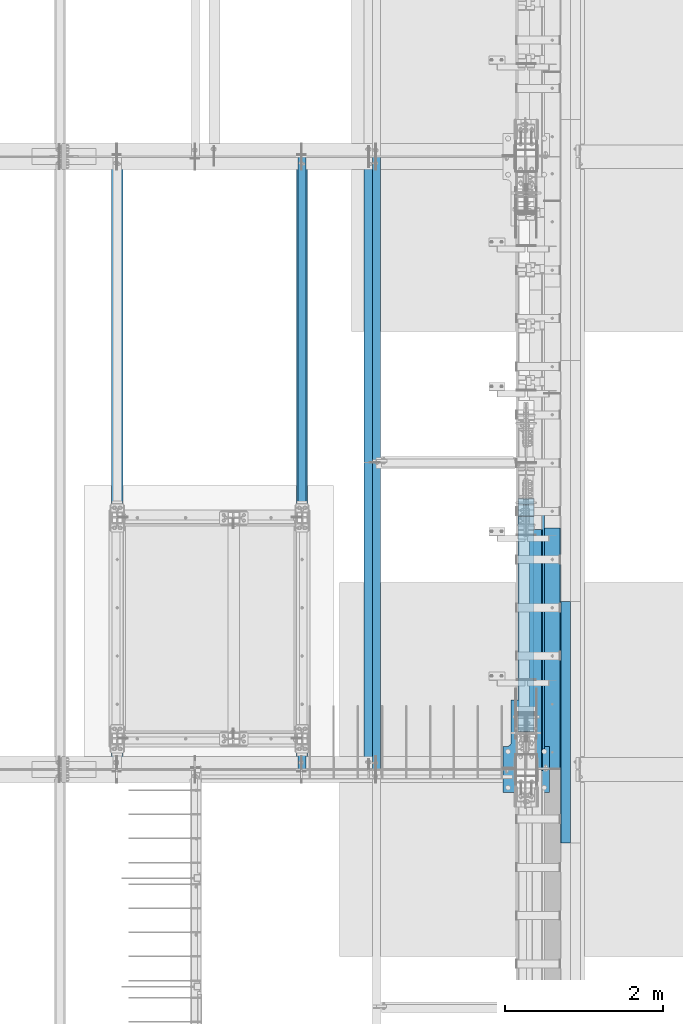
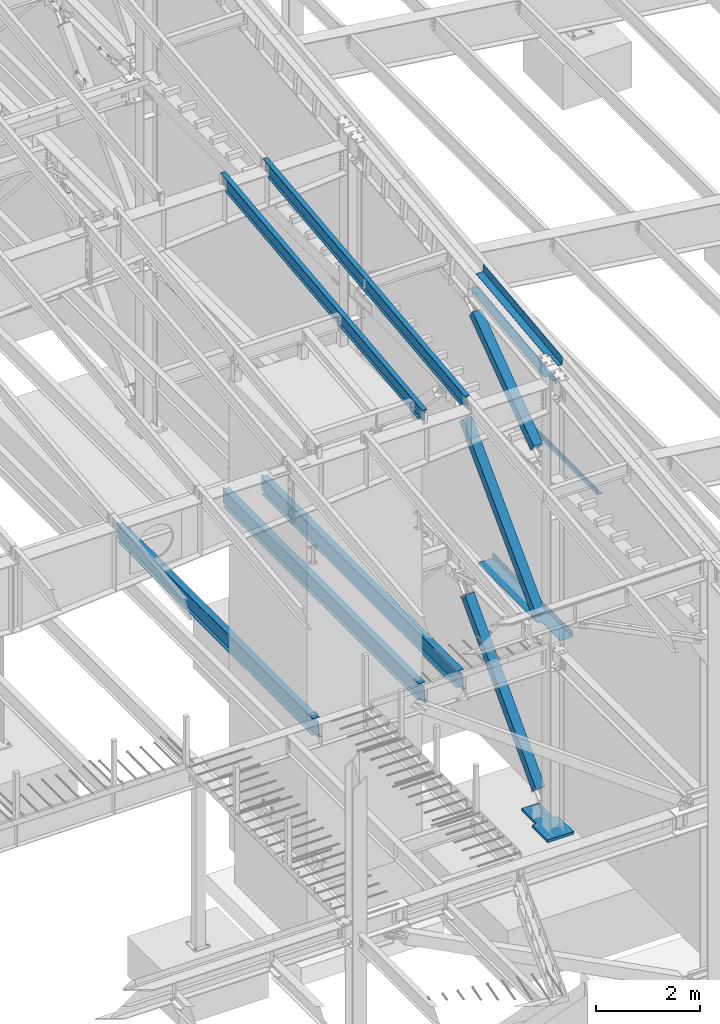
# One storey, part 723 of 1179: 10 beams, 3 members, 12 elements without a shape of their own.
"""IFC2X3 building model written with IfcOpenShell, lengths in millimetres."""

from ifc_helpers import new_model, si_unit, frame, origin_with_axes, place, context, subcontext, project, spatial, faceted_brep, material, type_object, element, aggregate, save


model = new_model("IFC2X3")

# Units and contexts
model_context = context("Model", 3, precision=1e-05, world=origin_with_axes())
body_context = subcontext(model_context, "Body", "Model", "MODEL_VIEW")
ifc_project = project(units=[si_unit("LENGTHUNIT", "METRE", prefix="MILLI"), si_unit("AREAUNIT", "SQUARE_METRE"), si_unit("VOLUMEUNIT", "CUBIC_METRE"), si_unit("MASSUNIT", "GRAM", prefix="KILO"), si_unit("TIMEUNIT", "SECOND"), si_unit("PLANEANGLEUNIT", "RADIAN"), si_unit("SOLIDANGLEUNIT", "STERADIAN"), si_unit("THERMODYNAMICTEMPERATUREUNIT", "DEGREE_CELSIUS"), si_unit("LUMINOUSINTENSITYUNIT", "LUMEN")], contexts=[model_context])

# Site, building, storey
site_placement = place(None, origin_with_axes())
site = spatial("IfcSite", under=ifc_project, at=site_placement, CompositionType="ELEMENT")
building_placement = place(site_placement, origin_with_axes())
building = spatial("IfcBuilding", under=site, at=building_placement, Name="Undefined", CompositionType="ELEMENT")
storey_placement = place(building_placement, origin_with_axes())
storey = spatial("IfcBuildingStorey", under=building, at=storey_placement, Name="Undefined", CompositionType="ELEMENT", Elevation=0.0)

# Assembly, beam
assembly_1_placement = place(storey_placement, origin_with_axes())
assembly_1 = element("IfcElementAssembly", 1, at=assembly_1_placement, inside=storey, Name="BEAM", AssemblyPlace="NOTDEFINED", PredefinedType="RIGID_FRAME")
ifc_material_1 = material(Name="STEEL/A992")
beam_type_1 = type_object("IfcBeamType", Name="W16X31", PredefinedType="NOTDEFINED")
beam_1_placement = place(assembly_1_placement, frame((21475.7, 11480.8, 3900.4875), z_axis=(0.0, 0.0, 1.0), x_axis=(0.0, 1.0, 0.0)))
beam_1 = element("IfcBeam", 2, at=beam_1_placement, type_object=beam_type_1, material=ifc_material_1, Name="BEAM", ObjectType="W16X31", context=body_context, shape_type="Brep", body=[
    faceted_brep([(104.775000190735, -3.17499999999927, 169.8625), (104.775000190735, 3.17497090526012, 169.8625), (17.4625000000015, 3.17499999999927, 169.8625), (17.4625000000015, -3.17499999999927, 169.8625), (109.635079708782, -3.17499999999927, 170.829229922588), (109.635079708782, 3.17497028100843, 170.829229922588), (113.755256176935, -3.17499999999927, 173.582243823066), (113.755256176935, 3.17496850329189, 173.582243823066), (116.508270077413, -3.17499999999927, 177.702420291219), (116.508270077413, 3.17496584275432, 177.702420291219), (117.475, -3.17499999999927, 182.562499809265), (117.475, 3.17496270443371, 182.562499809265), (117.474999999999, -69.8499999999985, 201.6125), (117.474999999999, 69.8499999999985, 201.6125), (117.474999999999, 69.8499999999985, 190.5), (117.474999999999, 3.17499999999927, 190.5), (117.474999999999, -3.17499999999927, 190.5), (117.474999999999, -69.8499999999985, 190.5), (7601.74375, 3.17499999999927, -190.5), (7601.74375, 69.8499999999985, -190.5), (144.462499999994, 69.8499999999985, -190.5), (144.462499999994, 3.17549991607666, -190.5), (17.4624999999942, -3.17499999999927, -190.5), (17.4624999999942, -69.8499999999985, -190.5), (7728.74375, -69.8499999999985, -190.5), (7728.74375, -3.17499999999927, -190.5), (17.4624999999942, -69.8499999999985, -201.6125), (7728.74375, -69.8499999999985, -201.6125), (7601.74375, 69.8499999999985, -201.6125), (7601.74375, 3.17561705897606, -201.6125), (7728.74375, 3.17561705897606, -201.6125), (17.4624999999942, 3.17549991607666, -201.6125), (144.462499999994, 3.17549991607666, -201.6125), (144.462499999994, 69.8499999999985, -201.6125), (17.4624999999942, 3.17499999999927, -190.5), (7728.74375, 3.17499999999927, -190.5), (7728.74375, 3.17499999999927, 169.8625), (7728.74375, -3.17499999999927, 169.8625), (7633.49374980927, 3.17499999999927, 169.8625), (7633.49374980927, -3.17499999999927, 169.8625), (7628.63367029122, 3.17499999999927, 170.829229922588), (7628.63367029122, -3.17499999999927, 170.829229922588), (7624.51349382307, 3.17499999999927, 173.582243823066), (7624.51349382307, -3.17499999999927, 173.582243823066), (7621.76047992259, 3.17499999999927, 177.70242029122), (7621.76047992259, -3.17499999999927, 177.70242029122), (7620.79375, 3.17499999999927, 182.562499809265), (7620.79375, -3.17499999999927, 182.562499809265), (7620.79375, -69.8499999999985, 201.6125), (7620.79375, -69.8499999999985, 190.5), (7620.79375, -3.17499999999927, 190.5), (7620.79375, 3.17499999999927, 190.5), (7620.79375, 69.8499999999985, 190.5), (7620.79375, 69.8499999999985, 201.6125)], [[[0, 1, 2, 3]], [[4, 5, 1, 0]], [[6, 7, 5, 4]], [[8, 9, 7, 6]], [[10, 11, 9, 8]], [[12, 13, 14, 15, 11, 10, 16, 17]], [[18, 19, 20, 21]], [[22, 23, 24, 25]], [[23, 26, 27, 24]], [[28, 29, 30, 27, 26, 31, 32, 33]], [[21, 32, 31, 34]], [[20, 33, 32, 21]], [[19, 28, 33, 20]], [[18, 29, 28, 19]], [[35, 30, 29, 18]], [[25, 24, 27, 30, 35, 36, 37]], [[37, 36, 38, 39]], [[39, 38, 40, 41]], [[41, 40, 42, 43]], [[43, 42, 44, 45]], [[45, 44, 46, 47]], [[48, 49, 50, 47, 46, 51, 52, 53]], [[49, 48, 12, 17]], [[50, 49, 17, 16]], [[8, 6, 4, 0, 3, 22, 25, 37, 39, 41, 43, 45, 47, 50, 16, 10]], [[34, 31, 26, 23, 22, 3, 2]], [[51, 46, 44, 42, 40, 38, 36, 35, 18, 21, 34, 2, 1, 5, 7, 9, 11, 15]], [[52, 51, 15, 14]], [[53, 52, 14, 13]], [[48, 53, 13, 12]]]),
])
aggregate(assembly_1, [beam_1])

assembly_2_placement = place(storey_placement, origin_with_axes())
assembly_2 = element("IfcElementAssembly", 3, at=assembly_2_placement, inside=storey, Name="BEAM", AssemblyPlace="NOTDEFINED", PredefinedType="RIGID_FRAME")
beam_2_placement = place(assembly_2_placement, frame((19138.9, 11480.8, 3900.4875), z_axis=(0.0, 0.0, 1.0), x_axis=(0.0, 1.0, 0.0)))
beam_2 = element("IfcBeam", 4, at=beam_2_placement, type_object=beam_type_1, material=ifc_material_1, Name="BEAM", ObjectType="W16X31", context=body_context, shape_type="Brep", body=[
    faceted_brep([(104.775000190735, -3.17499999999927, 169.8625), (104.775000190735, 3.17497090526012, 169.8625), (17.4625000000015, 3.17499999999927, 169.8625), (17.4625000000015, -3.17499999999927, 169.8625), (109.635079708782, -3.17499999999927, 170.829229922588), (109.635079708782, 3.17497028100843, 170.829229922588), (113.755256176935, -3.17499999999927, 173.582243823066), (113.755256176935, 3.17496850329189, 173.582243823066), (116.508270077413, -3.17499999999927, 177.702420291219), (116.508270077413, 3.17496584275432, 177.702420291219), (117.475, -3.17499999999927, 182.562499809265), (117.475, 3.17496270443371, 182.562499809265), (117.474999999999, -69.8499999999985, 201.6125), (117.474999999999, 69.8499999999985, 201.6125), (117.474999999999, 69.8499999999985, 190.5), (117.474999999999, 3.17499999999927, 190.5), (117.474999999999, -3.17499999999927, 190.5), (117.474999999999, -69.8499999999985, 190.5), (7601.74375, 3.17499999999927, -190.5), (7601.74375, 69.8499999999985, -190.5), (144.462499999994, 69.8499999999985, -190.5), (144.462499999994, 3.17549991607666, -190.5), (17.4624999999942, -3.17499999999927, -190.5), (17.4624999999942, -69.8499999999985, -190.5), (7728.74375, -69.8499999999985, -190.5), (7728.74375, -3.17499999999927, -190.5), (17.4624999999942, -69.8499999999985, -201.6125), (7728.74375, -69.8499999999985, -201.6125), (7601.74375, 69.8499999999985, -201.6125), (7601.74375, 3.17561705897606, -201.6125), (7728.74375, 3.17561705897606, -201.6125), (17.4624999999942, 3.17549991607666, -201.6125), (144.462499999994, 3.17549991607666, -201.6125), (144.462499999994, 69.8499999999985, -201.6125), (17.4624999999942, 3.17499999999927, -190.5), (7728.74375, 3.17499999999927, -190.5), (7728.74375, 3.17499999999927, 169.8625), (7728.74375, -3.17499999999927, 169.8625), (7633.49374980927, 3.17499999999927, 169.8625), (7633.49374980927, -3.17499999999927, 169.8625), (7628.63367029122, 3.17499999999927, 170.829229922588), (7628.63367029122, -3.17499999999927, 170.829229922588), (7624.51349382307, 3.17499999999927, 173.582243823066), (7624.51349382307, -3.17499999999927, 173.582243823066), (7621.76047992259, 3.17499999999927, 177.70242029122), (7621.76047992259, -3.17499999999927, 177.70242029122), (7620.79375, 3.17499999999927, 182.562499809265), (7620.79375, -3.17499999999927, 182.562499809265), (7620.79375, -69.8499999999985, 201.6125), (7620.79375, -69.8499999999985, 190.5), (7620.79375, -3.17499999999927, 190.5), (7620.79375, 3.17499999999927, 190.5), (7620.79375, 69.8499999999985, 190.5), (7620.79375, 69.8499999999985, 201.6125)], [[[0, 1, 2, 3]], [[4, 5, 1, 0]], [[6, 7, 5, 4]], [[8, 9, 7, 6]], [[10, 11, 9, 8]], [[12, 13, 14, 15, 11, 10, 16, 17]], [[18, 19, 20, 21]], [[22, 23, 24, 25]], [[23, 26, 27, 24]], [[28, 29, 30, 27, 26, 31, 32, 33]], [[21, 32, 31, 34]], [[20, 33, 32, 21]], [[19, 28, 33, 20]], [[18, 29, 28, 19]], [[35, 30, 29, 18]], [[25, 24, 27, 30, 35, 36, 37]], [[37, 36, 38, 39]], [[39, 38, 40, 41]], [[41, 40, 42, 43]], [[43, 42, 44, 45]], [[45, 44, 46, 47]], [[48, 49, 50, 47, 46, 51, 52, 53]], [[49, 48, 12, 17]], [[50, 49, 17, 16]], [[8, 6, 4, 0, 3, 22, 25, 37, 39, 41, 43, 45, 47, 50, 16, 10]], [[34, 31, 26, 23, 22, 3, 2]], [[51, 46, 44, 42, 40, 38, 36, 35, 18, 21, 34, 2, 1, 5, 7, 9, 11, 15]], [[52, 51, 15, 14]], [[53, 52, 14, 13]], [[48, 53, 13, 12]]]),
])
aggregate(assembly_2, [beam_2])

assembly_3_placement = place(storey_placement, origin_with_axes())
assembly_3 = element("IfcElementAssembly", 5, at=assembly_3_placement, inside=storey, Name="BEAM", AssemblyPlace="NOTDEFINED", PredefinedType="RIGID_FRAME")
beam_3_placement = place(assembly_3_placement, frame((22326.6, 11480.8, 3900.4875), z_axis=(0.0, 0.0, 1.0), x_axis=(0.0, 1.0, 0.0)))
beam_3 = element("IfcBeam", 6, at=beam_3_placement, type_object=beam_type_1, material=ifc_material_1, Name="BEAM", ObjectType="W16X31", context=body_context, shape_type="Brep", body=[
    faceted_brep([(104.775000190735, -3.17499999999927, 169.8625), (104.775000190735, 3.17497090526012, 169.8625), (17.4625000000015, 3.17499999999927, 169.8625), (17.4625000000015, -3.17499999999927, 169.8625), (109.635079708782, -3.17499999999927, 170.829229922588), (109.635079708782, 3.17497028100843, 170.829229922588), (113.755256176935, -3.17499999999927, 173.582243823066), (113.755256176935, 3.17496850329189, 173.582243823066), (116.508270077413, -3.17499999999927, 177.702420291219), (116.508270077413, 3.17496584275432, 177.702420291219), (117.475, -3.17499999999927, 182.562499809265), (117.475, 3.17496270443371, 182.562499809265), (117.474999999999, -69.8499999999985, 201.6125), (117.474999999999, 69.8499999999985, 201.6125), (117.474999999999, 69.8499999999985, 190.5), (117.474999999999, 3.17499999999927, 190.5), (117.474999999999, -3.17499999999927, 190.5), (117.474999999999, -69.8499999999985, 190.5), (7601.74375, 3.17499999999927, -190.5), (7601.74375, 69.8499999999985, -190.5), (144.462499999994, 69.8499999999985, -190.5), (144.462499999994, 3.17549991607666, -190.5), (17.4624999999942, -3.17499999999927, -190.5), (17.4624999999942, -69.8499999999985, -190.5), (7728.74375, -69.8499999999985, -190.5), (7728.74375, -3.17499999999927, -190.5), (17.4624999999942, -69.8499999999985, -201.6125), (7728.74375, -69.8499999999985, -201.6125), (7601.74375, 69.8499999999985, -201.6125), (7601.74375, 3.17561705897606, -201.6125), (7728.74375, 3.17561705897606, -201.6125), (17.4624999999942, 3.17549991607666, -201.6125), (144.462499999994, 3.17549991607666, -201.6125), (144.462499999994, 69.8499999999985, -201.6125), (17.4624999999942, 3.17499999999927, -190.5), (7728.74375, 3.17499999999927, -190.5), (7728.74375, 3.17499999999927, 169.8625), (7728.74375, -3.17499999999927, 169.8625), (7633.49374980927, 3.17499999999927, 169.8625), (7633.49374980927, -3.17499999999927, 169.8625), (7628.63367029122, 3.17499999999927, 170.829229922588), (7628.63367029122, -3.17499999999927, 170.829229922588), (7624.51349382307, 3.17499999999927, 173.582243823066), (7624.51349382307, -3.17499999999927, 173.582243823066), (7621.76047992259, 3.17499999999927, 177.70242029122), (7621.76047992259, -3.17499999999927, 177.70242029122), (7620.79375, 3.17499999999927, 182.562499809265), (7620.79375, -3.17499999999927, 182.562499809265), (7620.79375, -69.8499999999985, 201.6125), (7620.79375, -69.8499999999985, 190.5), (7620.79375, -3.17499999999927, 190.5), (7620.79375, 3.17499999999927, 190.5), (7620.79375, 69.8499999999985, 190.5), (7620.79375, 69.8499999999985, 201.6125)], [[[0, 1, 2, 3]], [[4, 5, 1, 0]], [[6, 7, 5, 4]], [[8, 9, 7, 6]], [[10, 11, 9, 8]], [[12, 13, 14, 15, 11, 10, 16, 17]], [[18, 19, 20, 21]], [[22, 23, 24, 25]], [[23, 26, 27, 24]], [[28, 29, 30, 27, 26, 31, 32, 33]], [[21, 32, 31, 34]], [[20, 33, 32, 21]], [[19, 28, 33, 20]], [[18, 29, 28, 19]], [[35, 30, 29, 18]], [[25, 24, 27, 30, 35, 36, 37]], [[37, 36, 38, 39]], [[39, 38, 40, 41]], [[41, 40, 42, 43]], [[43, 42, 44, 45]], [[45, 44, 46, 47]], [[48, 49, 50, 47, 46, 51, 52, 53]], [[49, 48, 12, 17]], [[50, 49, 17, 16]], [[8, 6, 4, 0, 3, 22, 25, 37, 39, 41, 43, 45, 47, 50, 16, 10]], [[34, 31, 26, 23, 22, 3, 2]], [[51, 46, 44, 42, 40, 38, 36, 35, 18, 21, 34, 2, 1, 5, 7, 9, 11, 15]], [[52, 51, 15, 14]], [[53, 52, 14, 13]], [[48, 53, 13, 12]]]),
])
aggregate(assembly_3, [beam_3])

assembly_4_placement = place(storey_placement, origin_with_axes())
assembly_4 = element("IfcElementAssembly", 7, at=assembly_4_placement, inside=storey, Name="BEAM", AssemblyPlace="NOTDEFINED", PredefinedType="RIGID_FRAME")
ifc_material_2 = material(Name="STEEL/A36")
beam_type_2 = type_object("IfcBeamType", PredefinedType="NOTDEFINED")
beam_4_placement = place(assembly_4_placement, frame((24350.663, 12997.8759537224, 10718.8180795381), z_axis=(0.0, -0.993676146336441, -0.112284087038017), x_axis=(1.0, 0.0, 0.0)))
beam_4 = element("IfcBeam", 8, at=beam_4_placement, type_object=beam_type_2, material=ifc_material_2, Name="BENT_PLATE", context=body_context, shape_type="Brep", body=[
    faceted_brep([(71.4352009224931, -3.17499187418616, 1106.33253533119), (71.4352351084999, 3.17500000045038, 1106.33379663171), (7.27595761418343e-12, 3.17500000044856, 1106.33381089825), (7.27595761418343e-12, -3.17499999954634, 1106.33254967412), (71.4347189428845, -3.25795323928105, 1523.99986037682), (71.4347535755223, 3.17500000061955, 1523.99999999914), (160.337000000047, -3.17500000061591, -1523.99999999915), (0.0, -3.17499999999927, -1524.0), (0.0, 3.17499999999927, -1524.0), (153.987000022519, 3.17500000077052, -1524.00000000059), (153.987000000016, 187.324999998867, -1523.99999999923), (160.337000000014, 187.324999998867, -1523.99999999923), (153.987000024775, 3.17499999922438, 1524.00000000046), (153.987000000016, 187.325000000103, 1523.99999999907), (160.337000000014, 187.325000000103, 1523.99999999907), (160.336999999981, -3.17499999938082, 1523.99999999915)], [[[0, 1, 2, 3]], [[4, 5, 1, 0]], [[6, 7, 8, 9, 10, 11]], [[9, 12, 13, 10]], [[14, 11, 10, 13]], [[15, 6, 11, 14]], [[3, 7, 6, 15, 4, 0]], [[8, 7, 3, 2]], [[12, 9, 8, 2, 1, 5]], [[15, 14, 13, 12, 5, 4]]]),
])

# Assembly, member
assembly_5_placement = place(storey_placement, origin_with_axes())
assembly_5 = element("IfcElementAssembly", 9, at=assembly_5_placement, inside=storey, Name="None", AssemblyPlace="NOTDEFINED", PredefinedType="RIGID_FRAME")
member_type = type_object("IfcMemberType", Name="HSS8X8X3/16", PredefinedType="NOTDEFINED")
member_1_placement = place(assembly_5_placement, frame((24307.8, 12102.6818031722, 8317.93316623901), z_axis=(1.0, 0.0, 0.0), x_axis=(0.0, 0.806042322895357, 0.591857899923163)))
member_1 = element("IfcMember", 10, at=member_1_placement, type_object=member_type, material=ifc_material_1, Name="None", ObjectType="HSS8X8X3/16", context=body_context, shape_type="Brep", body=[
    faceted_brep([(-3.63797880709171e-12, 96.8374999999978, -96.8375000000015), (-3.63797880709171e-12, -96.8374999999978, -96.8375000000015), (2914.65000001991, -96.8374999971984, -96.8375), (2914.65000001972, 96.8375000027499, -96.8375), (-3.63797880709171e-12, -96.8374999999978, 96.8375000000015), (2914.65000001991, -96.8374999971984, 96.8375), (-3.63797880709171e-12, 96.8374999999978, 96.8375000000015), (2914.65000001972, 96.8375000027499, 96.8375), (-3.63797880709171e-12, 101.599999999999, -101.599999999999), (-3.63797880709171e-12, 101.599999999999, 101.599999999999), (2914.65000001972, 101.600000002747, 101.6), (2914.65000001972, 101.600000002747, -101.6), (0.0, -101.599999999999, 101.599999999999), (2914.65000001991, -101.599999997197, 101.6), (0.0, -101.599999999999, -101.599999999999), (2914.65000001991, -101.599999997197, -101.6)], [[[0, 1, 2, 3]], [[1, 4, 5, 2]], [[4, 6, 7, 5]], [[6, 0, 3, 7]], [[8, 9, 10, 11]], [[9, 12, 13, 10]], [[12, 14, 15, 13]], [[14, 8, 11, 15]], [[13, 15, 11, 10], [5, 7, 3, 2]], [[14, 12, 9, 8], [6, 4, 1, 0]]]),
])
aggregate(assembly_5, [member_1])

assembly_6_placement = place(storey_placement, origin_with_axes())
assembly_6 = element("IfcElementAssembly", 11, at=assembly_6_placement, inside=storey, Name="None", AssemblyPlace="NOTDEFINED", PredefinedType="RIGID_FRAME")
member_2_placement = place(assembly_6_placement, frame((24307.8, 12024.6149486083, 4449.73744723826), z_axis=(1.0, 0.0, 0.0), x_axis=(0.0, 0.698466923036852, 0.715642339037758)))
member_2 = element("IfcMember", 12, at=member_2_placement, type_object=member_type, material=ifc_material_1, Name="None", ObjectType="HSS8X8X3/16", context=body_context, shape_type="Brep", body=[
    faceted_brep([(-3.63797880709171e-12, 96.8374999999978, -96.8375000000015), (-3.63797880709171e-12, -96.8374999999978, -96.8375000000015), (4020.12294193522, -96.8374999996613, -96.8375), (4020.12294193534, 96.8375000002416, -96.8375), (-3.63797880709171e-12, -96.8374999999978, 96.8375000000015), (4020.12294193522, -96.8374999996613, 96.8375), (-3.63797880709171e-12, 96.8374999999978, 96.8375000000015), (4020.12294193534, 96.8375000002416, 96.8375), (-3.63797880709171e-12, 101.599999999999, -101.599999999999), (-3.63797880709171e-12, 101.599999999999, 101.599999999999), (4020.12294193534, 101.600000000239, 101.6), (4020.12294193534, 101.600000000239, -101.6), (0.0, -101.599999999999, 101.599999999999), (4020.12294193522, -101.59999999966, 101.6), (0.0, -101.599999999999, -101.599999999999), (4020.12294193522, -101.59999999966, -101.6)], [[[0, 1, 2, 3]], [[1, 4, 5, 2]], [[4, 6, 7, 5]], [[6, 0, 3, 7]], [[8, 9, 10, 11]], [[9, 12, 13, 10]], [[12, 14, 15, 13]], [[14, 8, 11, 15]], [[13, 15, 11, 10], [5, 7, 3, 2]], [[14, 12, 9, 8], [6, 4, 1, 0]]]),
])
aggregate(assembly_6, [member_2])

assembly_7_placement = place(storey_placement, origin_with_axes())
assembly_7 = element("IfcElementAssembly", 13, at=assembly_7_placement, inside=storey, Name="None", AssemblyPlace="NOTDEFINED", PredefinedType="RIGID_FRAME")
member_3_placement = place(assembly_7_placement, frame((24307.8, 12032.5736527125, 369.341890750089), z_axis=(1.0, 0.0, 0.0), x_axis=(0.0, 0.685995858758672, 0.727605443744034)))
member_3 = element("IfcMember", 14, at=member_3_placement, type_object=member_type, material=ifc_material_1, Name="None", ObjectType="HSS8X8X3/16", context=body_context, shape_type="Brep", body=[
    faceted_brep([(-3.63797880709171e-12, 96.8374999999978, -96.8375000000015), (-3.63797880709171e-12, -96.8374999999978, -96.8375000000015), (3968.75000001255, -96.8375000016003, -96.8375), (3968.75000001275, 96.8374999981806, -96.8375), (-3.63797880709171e-12, -96.8374999999978, 96.8375000000015), (3968.75000001255, -96.8375000016003, 96.8375), (-3.63797880709171e-12, 96.8374999999978, 96.8375000000015), (3968.75000001275, 96.8374999981806, 96.8375), (-3.63797880709171e-12, 101.599999999999, -101.599999999999), (-3.63797880709171e-12, 101.599999999999, 101.599999999999), (3968.75000001276, 101.599999998176, 101.6), (3968.75000001276, 101.599999998176, -101.6), (0.0, -101.599999999999, 101.599999999999), (3968.75000001255, -101.600000001596, 101.6), (0.0, -101.599999999999, -101.599999999999), (3968.75000001255, -101.600000001596, -101.6)], [[[0, 1, 2, 3]], [[1, 4, 5, 2]], [[4, 6, 7, 5]], [[6, 0, 3, 7]], [[8, 9, 10, 11]], [[9, 12, 13, 10]], [[12, 14, 15, 13]], [[14, 8, 11, 15]], [[13, 15, 11, 10], [5, 7, 3, 2]], [[14, 12, 9, 8], [6, 4, 1, 0]]]),
])
aggregate(assembly_7, [member_3])

# Beam
beam_type_3 = type_object("IfcBeamType", PredefinedType="NOTDEFINED")
beam_5_placement = place(assembly_4_placement, frame((24350.6629997725, 13255.868948985, 10219.1643500463), z_axis=(0.0, -0.993676146336441, -0.112284087038017), x_axis=(1.0, 0.0, 0.0)))
beam_5 = element("IfcBeam", 15, at=beam_5_placement, type_object=beam_type_3, material=ifc_material_2, Name="BENT_PLATE", context=body_context, shape_type="Brep", body=[
    faceted_brep([(76.1995002270851, -3.17499964067611, -1324.93565701638), (76.1995002270851, 3.17561397314239, -1324.93565701637), (-7.27595761418343e-12, 3.17499999946085, -1324.93565701637), (-7.27595761418343e-12, -3.17500000053587, -1324.93565701638), (76.1995002270851, -3.17499964067065, -1309.06065701654), (76.1995002270851, 3.17561397314785, -1309.06065701656), (-7.27595761418343e-12, -3.1750000005286, -1309.06065701654), (-7.27595761418343e-12, 3.17499999946995, -1309.06065701656), (179.387000000001, -3.17499999999927, 1524.0), (179.387000000001, -3.17499999999927, -1524.0), (179.387000226754, -136.524387938527, -1523.99999999909), (179.387000226754, -136.52438793729, 1523.9999999992), (76.1995002269396, -3.17510786902676, 1377.94999996143), (76.1995002269396, 3.17550574472261, 1377.94999996396), (7.27595761418343e-12, 3.17500000055588, 1377.94999996396), (7.27595761418343e-12, -3.1749999994372, 1377.94999996142), (76.1995002269396, -3.17561361185653, 1523.999999945), (76.1995002269396, 3.17500000061045, 1523.99999999914), (185.737000226753, -136.52438793729, 1523.9999999992), (185.737000000001, 3.17499999999927, 1524.0), (185.737000000001, 3.17499999999927, -1524.0), (185.737000226753, -136.524387938527, -1523.99999999909), (0.0, -3.17499999999927, -1524.0), (0.0, 3.17499999999927, -1524.0)], [[[0, 1, 2, 3]], [[4, 5, 1, 0]], [[6, 7, 5, 4]], [[8, 9, 10, 11]], [[12, 13, 14, 15]], [[16, 17, 13, 12]], [[8, 11, 18, 19, 17, 16]], [[20, 19, 18, 21]], [[11, 10, 21, 18]], [[9, 22, 23, 20, 21, 10]], [[23, 22, 3, 2]], [[14, 13, 17, 19, 20, 23, 2, 1, 5, 7]], [[15, 14, 7, 6]], [[3, 22, 9, 8, 16, 12, 15, 6, 4, 0]]]),
])

aggregate(assembly_4, [beam_4, beam_5])

# Assembly, beam
assembly_8_placement = place(storey_placement, origin_with_axes())
assembly_8 = element("IfcElementAssembly", 16, at=assembly_8_placement, inside=storey, Name="BEAM", AssemblyPlace="NOTDEFINED", PredefinedType="RIGID_FRAME")
beam_type_4 = type_object("IfcBeamType", PredefinedType="NOTDEFINED")
beam_6_placement = place(assembly_8_placement, frame((24387.175012207, 13007.975, 4105.275), z_axis=(0.0, -1.0, 0.0), x_axis=(1.0, 0.0, 0.0)))
beam_6 = element("IfcBeam", 17, at=beam_6_placement, type_object=beam_type_4, material=ifc_material_2, Name="BENT_PLATE", context=body_context, shape_type="Brep", body=[
    faceted_brep([(84.1374893188476, -3.17500000000018, 788.651567305722), (84.1374893188476, 3.17500000000018, 788.651567305722), (0.0, 3.17500000000018, 788.651567305722), (0.0, -3.17500000000018, 788.651567305722), (84.1374893188477, -3.17500000000018, 1524.0), (84.1374893188477, 3.17500000000018, 1524.0), (352.424987792969, -3.17499999999927, -1524.0), (0.0, -3.17499999999927, -1524.0), (0.0, 3.17499999999927, -1524.0), (346.07498779297, 3.17500000000109, -1524.0), (346.07498779297, 130.175006103515, -1524.0), (352.424987792969, 130.175006103515, -1524.0), (346.07498779297, 3.17500000000109, 1524.0), (346.07498779297, 130.175006103515, 1524.0), (352.424987792969, 130.175006103515, 1524.0), (352.424987792969, -3.17499999999927, 1524.0)], [[[0, 1, 2, 3]], [[4, 5, 1, 0]], [[6, 7, 8, 9, 10, 11]], [[9, 12, 13, 10]], [[14, 11, 10, 13]], [[15, 6, 11, 14]], [[3, 7, 6, 15, 4, 0]], [[8, 7, 3, 2]], [[12, 9, 8, 2, 1, 5]], [[15, 14, 13, 12, 5, 4]]]),
])
aggregate(assembly_8, [beam_6])

assembly_9_placement = place(storey_placement, origin_with_axes())
assembly_9 = element("IfcElementAssembly", 18, at=assembly_9_placement, inside=storey, Name="BENT_PLATE", AssemblyPlace="NOTDEFINED", PredefinedType="RIGID_FRAME")
beam_type_5 = type_object("IfcBeamType", PredefinedType="NOTDEFINED")
beam_7_placement = place(assembly_9_placement, frame((24744.362499997, 12077.6999999996, 8102.29217706219), z_axis=(0.0, 1.0, 0.0), x_axis=(0.0, 0.0, -1.0)))
beam_7 = element("IfcBeam", 19, at=beam_7_placement, type_object=beam_type_5, material=ifc_material_2, Name="BENT_PLATE", context=body_context, shape_type="Brep", body=[
    faceted_brep([(-2.91038304567337e-11, -4.76250000000073, -1524.0), (-2.91038304567337e-11, -4.76250000000073, 1524.0), (2.91038304567337e-11, 4.76250000000073, 1524.0), (2.91038304567337e-11, 4.76250000000073, -1524.0), (114.300008765535, 4.76250001759399, 1524.0000000001), (114.300003051474, 4.7625000005828, -1524.0), (105.977955544956, -4.76249999945867, -1524.0), (105.977955544956, -4.76249999945867, 1524.0), (131.343048095475, -121.088742065571, 1524.0), (131.343048095475, -121.088742065571, -1524.0), (121.904205090902, -122.366970423507, 1524.0), (121.904205090902, -122.366970423507, -1524.0)], [[[0, 1, 2, 3]], [[3, 2, 4, 5]], [[1, 0, 6, 7]], [[5, 4, 8, 9]], [[4, 2, 1, 7, 10, 8]], [[7, 6, 11, 10]], [[6, 0, 3, 5, 9, 11]], [[10, 11, 9, 8]]]),
])
aggregate(assembly_9, [beam_7])

assembly_10_placement = place(storey_placement, origin_with_axes())
assembly_10 = element("IfcElementAssembly", 20, at=assembly_10_placement, inside=storey, Name="BEAM", AssemblyPlace="NOTDEFINED", PredefinedType="RIGID_FRAME")
beam_type_6 = type_object("IfcBeamType", Name="W12X22", PredefinedType="NOTDEFINED")
beam_8_placement = place(assembly_10_placement, frame((22415.5, 11498.2779321842, 10389.6051906331), z_axis=(0.0, -0.112284087038017, 0.993676146336441), x_axis=(0.0, 0.993676146336441, 0.112284087038017)))
beam_8 = element("IfcBeam", 21, at=beam_8_placement, type_object=beam_type_6, material=ifc_material_1, Name="BEAM", ObjectType="W12X22", context=body_context, shape_type="Brep", body=[
    faceted_brep([(7583.46730043383, -3.17499999999927, -144.462500002994), (7583.46730043383, -50.7999999999993, -144.462500002994), (7582.21160266769, -50.7999999999993, -155.575000002988), (7582.21160266769, 50.7999999999993, -155.575000002988), (7583.46730043383, 50.7999999999993, -144.462500002994), (7583.46730043383, 3.17499999999927, -144.462500002994), (7586.83832669432, 3.17499999999927, -114.630059163946), (7586.83832669432, -3.17499999999927, -114.630059163946), (7588.34465274973, 3.17499999999927, -109.909262464753), (7588.34465274973, -3.17499999999927, -109.909262464753), (7591.54288724583, 3.17499999999927, -106.124261042249), (7591.54288724583, -3.17499999999927, -106.124261042249), (7595.94612797272, 3.17499999999927, -103.851287051781), (7595.94612797272, -3.17499999999927, -103.851287051781), (7600.88402144536, 3.17499999999927, -103.436380178771), (7600.88402144536, -3.17499999999927, -103.436380178771), (7758.6208335002, -3.17499999999927, -121.260430776909), (7758.62083354224, 3.17499999999927, -121.26043078166), (6.38101702707718, -50.7999999999993, 155.574999999912), (5.12531926095107, -50.7999999999993, 144.46249999992), (7788.64717240277, -50.7999999999993, 144.462499996762), (7789.9028701689, -50.7999999999993, 155.574999996754), (6.38101702707718, 50.7999999999993, 155.574999999912), (7789.9028701689, 50.7999999999993, 155.574999996754), (5.12531926095107, 50.7999999999993, 144.46249999992), (7788.64717240277, 50.7999999999993, 144.462499996762), (5.12531926095107, 3.17499999999927, 144.46249999992), (7788.64717240277, 3.17499999999927, 144.462499996762), (145.30344487597, -3.17499999999927, -142.022226300664), (145.30344487597, 3.17499999999927, -142.022226300664), (145.027696926005, 3.17499999999927, -144.462499999976), (145.027696926005, 50.7999999999993, -144.462499999976), (143.771999161854, 50.7999999999993, -155.574999999972), (143.771999161854, -50.7999999999993, -155.574999999972), (145.027696926005, -50.7999999999993, -144.462499999976), (145.027696926005, -3.17499999999927, -144.462499999976), (-25.0716067072917, -3.17499999999927, -122.770071196437), (-25.0716067072917, 3.17499999999927, -122.770071196437), (5.12531926095107, -3.17499999999927, 144.46249999992), (7788.64717240277, -3.17499999999927, 144.462499996762)], [[[0, 1, 2, 3, 4, 5, 6, 7]], [[7, 6, 8, 9]], [[9, 8, 10, 11]], [[11, 10, 12, 13]], [[13, 12, 14, 15]], [[16, 15, 14, 17]], [[18, 19, 20, 21]], [[22, 18, 21, 23]], [[24, 22, 23, 25]], [[26, 24, 25, 27]], [[28, 29, 30, 31, 32, 33, 34, 35]], [[36, 37, 29, 28]], [[38, 19, 18, 22, 24, 26, 37, 36]], [[19, 38, 39, 20]], [[27, 25, 23, 21, 20, 39, 16, 17]], [[12, 10, 8, 6, 5, 30, 29, 37, 26, 27, 17, 14]], [[31, 30, 5, 4]], [[32, 31, 4, 3]], [[33, 32, 3, 2]], [[34, 33, 2, 1]], [[35, 34, 1, 0]], [[39, 38, 36, 28, 35, 0, 7, 9, 11, 13, 15, 16]]]),
])
aggregate(assembly_10, [beam_8])

assembly_11_placement = place(storey_placement, origin_with_axes())
assembly_11 = element("IfcElementAssembly", 22, at=assembly_11_placement, inside=storey, Name="BEAM", AssemblyPlace="NOTDEFINED", PredefinedType="RIGID_FRAME")
beam_9_placement = place(assembly_11_placement, frame((21475.7, 11498.2779321842, 10389.6051906331), z_axis=(0.0, -0.112284087038017, 0.993676146336441), x_axis=(0.0, 0.993676146336441, 0.112284087038017)))
beam_9 = element("IfcBeam", 23, at=beam_9_placement, type_object=beam_type_6, material=ifc_material_1, Name="BEAM", ObjectType="W12X22", context=body_context, shape_type="Brep", body=[
    faceted_brep([(7583.46730043383, -3.17499999999927, -144.462500002994), (7583.46730043383, -50.7999999999993, -144.462500002994), (7582.21160266769, -50.7999999999993, -155.575000002988), (7582.21160266769, 50.7999999999993, -155.575000002988), (7583.46730043383, 50.7999999999993, -144.462500002994), (7583.46730043383, 3.17499999999927, -144.462500002994), (7586.83832669432, 3.17499999999927, -114.630059163946), (7586.83832669432, -3.17499999999927, -114.630059163946), (7588.34465274973, 3.17499999999927, -109.909262464753), (7588.34465274973, -3.17499999999927, -109.909262464753), (7591.54288724583, 3.17499999999927, -106.124261042249), (7591.54288724583, -3.17499999999927, -106.124261042249), (7595.94612797272, 3.17499999999927, -103.851287051781), (7595.94612797272, -3.17499999999927, -103.851287051781), (7600.88402144536, 3.17499999999927, -103.436380178771), (7600.88402144536, -3.17499999999927, -103.436380178771), (7758.6208335002, -3.17499999999927, -121.260430776909), (7758.62083354224, 3.17499999999927, -121.26043078166), (6.38101702707718, -50.7999999999993, 155.574999999912), (5.12531926095107, -50.7999999999993, 144.46249999992), (7788.64717240277, -50.7999999999993, 144.462499996762), (7789.9028701689, -50.7999999999993, 155.574999996754), (6.38101702707718, 50.7999999999993, 155.574999999912), (7789.9028701689, 50.7999999999993, 155.574999996754), (5.12531926095107, 50.7999999999993, 144.46249999992), (7788.64717240277, 50.7999999999993, 144.462499996762), (5.12531926095107, 3.17499999999927, 144.46249999992), (7788.64717240277, 3.17499999999927, 144.462499996762), (145.30344487597, -3.17499999999927, -142.022226300664), (145.30344487597, 3.17499999999927, -142.022226300664), (145.027696926005, 3.17499999999927, -144.462499999976), (145.027696926005, 50.7999999999993, -144.462499999976), (143.771999161854, 50.7999999999993, -155.574999999972), (143.771999161854, -50.7999999999993, -155.574999999972), (145.027696926005, -50.7999999999993, -144.462499999976), (145.027696926005, -3.17499999999927, -144.462499999976), (-25.0716067072917, -3.17499999999927, -122.770071196437), (-25.0716067072917, 3.17499999999927, -122.770071196437), (5.12531926095107, -3.17499999999927, 144.46249999992), (7788.64717240277, -3.17499999999927, 144.462499996762)], [[[0, 1, 2, 3, 4, 5, 6, 7]], [[7, 6, 8, 9]], [[9, 8, 10, 11]], [[11, 10, 12, 13]], [[13, 12, 14, 15]], [[16, 15, 14, 17]], [[18, 19, 20, 21]], [[22, 18, 21, 23]], [[24, 22, 23, 25]], [[26, 24, 25, 27]], [[28, 29, 30, 31, 32, 33, 34, 35]], [[36, 37, 29, 28]], [[38, 19, 18, 22, 24, 26, 37, 36]], [[19, 38, 39, 20]], [[27, 25, 23, 21, 20, 39, 16, 17]], [[12, 10, 8, 6, 5, 30, 29, 37, 26, 27, 17, 14]], [[31, 30, 5, 4]], [[32, 31, 4, 3]], [[33, 32, 3, 2]], [[34, 33, 2, 1]], [[35, 34, 1, 0]], [[39, 38, 36, 28, 35, 0, 7, 9, 11, 13, 15, 16]]]),
])
aggregate(assembly_11, [beam_9])

assembly_12_placement = place(storey_placement, origin_with_axes())
assembly_12 = element("IfcElementAssembly", 24, at=assembly_12_placement, inside=storey, Name="COLUMN", AssemblyPlace="NOTDEFINED", PredefinedType="RIGID_FRAME")
ifc_material_3 = material(Name="STEEL/A572-GR.50")
beam_type_7 = type_object("IfcBeamType", PredefinedType="NOTDEFINED")
beam_10_placement = place(assembly_12_placement, frame((24307.8, 11188.70050354, -247.649999999999), z_axis=(-1.0, 0.0, 0.0), x_axis=(0.0, 1.0, 0.0)))
beam_10 = element("IfcBeam", 25, at=beam_10_placement, type_object=beam_type_7, material=ifc_material_3, context=body_context, shape_type="Brep", body=[
    faceted_brep([(584.199496459958, -31.75, 292.1), (584.199496459958, -31.75, 241.30000076336), (584.199496459958, 31.75, 241.30000076336), (584.199496459958, 31.75, 292.1), (588.066416150308, -31.75, 221.859682691178), (588.066416150308, 31.75, 221.859682691178), (599.078471752222, -31.75, 205.378976818563), (599.078471752222, 31.75, 205.378976818563), (615.559177624837, -31.75, 194.366921216651), (615.559177624837, 31.75, 194.366921216651), (634.999495697019, -31.75, 190.500001526299), (634.999495697019, 31.75, 190.500001526299), (1168.39847106933, -31.75, 190.500001526299), (1168.39848937988, 31.75, 190.500001526299), (0.0, -31.75, -292.1), (0.0, -31.75, 292.1), (0.0, 31.75, 292.1), (0.0, 31.75, -292.1), (584.199496459958, 31.75, -292.1), (584.199496459958, -31.75, -292.1), (584.199496459958, 31.75, -241.30000076336), (584.199496459958, -31.75, -241.30000076336), (588.066416150308, 31.75, -221.859682691178), (588.066416150308, -31.75, -221.859682691178), (599.078471752222, 31.75, -205.378976818563), (599.078471752222, -31.75, -205.378976818563), (615.559177624837, 31.75, -194.366921216651), (615.559177624837, -31.75, -194.366921216651), (634.999495697019, 31.75, -190.500001526299), (634.999495697019, -31.75, -190.500001526299), (1168.39847106933, -31.75, -190.500001526299), (1168.39848937988, 31.75, -190.500001526299)], [[[0, 1, 2, 3]], [[4, 5, 2, 1]], [[6, 7, 5, 4]], [[8, 9, 7, 6]], [[10, 11, 9, 8]], [[12, 13, 11, 10]], [[14, 15, 16, 17]], [[14, 17, 18, 19]], [[19, 18, 20, 21]], [[21, 20, 22, 23]], [[23, 22, 24, 25]], [[25, 24, 26, 27]], [[27, 26, 28, 29]], [[30, 29, 28, 31]], [[8, 6, 4, 1, 0, 15, 14, 19, 21, 23, 25, 27, 29, 30, 12, 10]], [[16, 15, 0, 3]], [[31, 28, 26, 24, 22, 20, 18, 17, 16, 3, 2, 5, 7, 9, 11, 13]], [[30, 31, 13, 12]]]),
])
aggregate(assembly_12, [beam_10])

save(model, "model.ifc")
